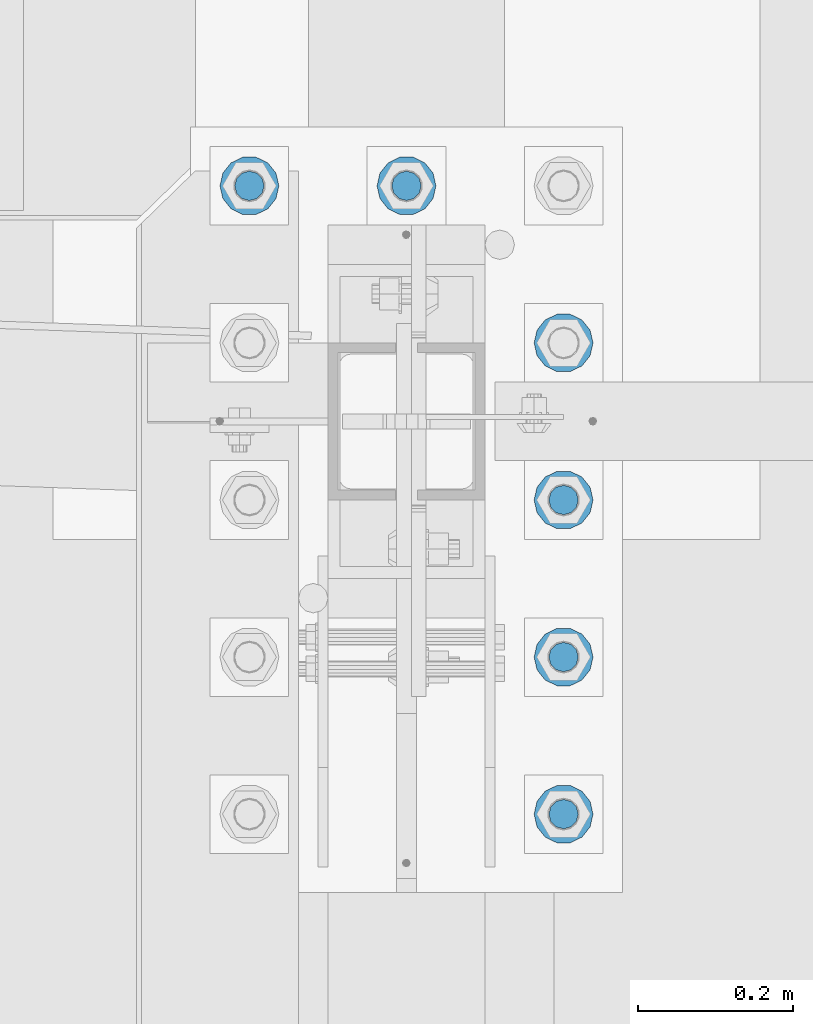
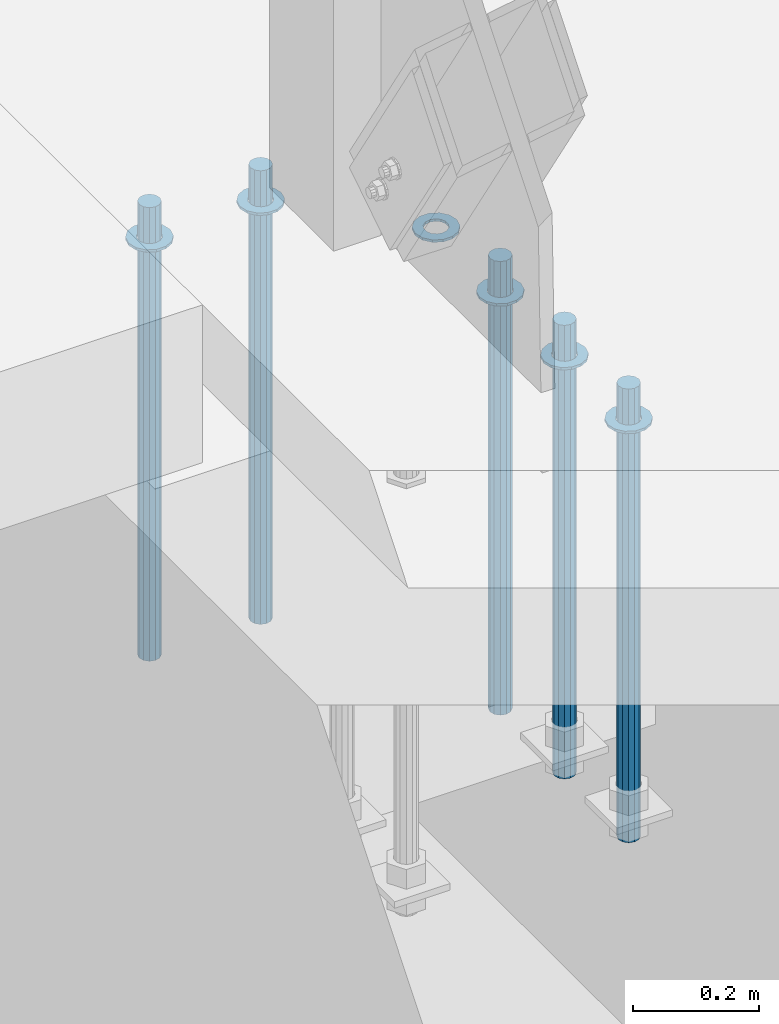
# One storey, part 926 of 1763: 11 columns, 1 element without a shape of its own.
"""IFC2X3 building model written with IfcOpenShell, lengths in millimetres."""

from ifc_helpers import new_model, si_unit, frame, origin_with_axes, place, context, subcontext, project, spatial, faceted_brep, material, type_object, element, aggregate, save


model = new_model("IFC2X3")

# Units and contexts
model_context = context("Model", 3, precision=1e-05, world=origin_with_axes())
body_context = subcontext(model_context, "Body", "Model", "MODEL_VIEW")
ifc_project = project(units=[si_unit("LENGTHUNIT", "METRE", prefix="MILLI"), si_unit("AREAUNIT", "SQUARE_METRE"), si_unit("VOLUMEUNIT", "CUBIC_METRE"), si_unit("MASSUNIT", "GRAM", prefix="KILO"), si_unit("TIMEUNIT", "SECOND"), si_unit("PLANEANGLEUNIT", "RADIAN"), si_unit("SOLIDANGLEUNIT", "STERADIAN"), si_unit("THERMODYNAMICTEMPERATUREUNIT", "DEGREE_CELSIUS"), si_unit("LUMINOUSINTENSITYUNIT", "LUMEN")], contexts=[model_context])

# Site, building, storey
site_placement = place(None, origin_with_axes())
site = spatial("IfcSite", under=ifc_project, at=site_placement, CompositionType="ELEMENT")
building_placement = place(site_placement, origin_with_axes())
building = spatial("IfcBuilding", under=site, at=building_placement, Name="Undefined", CompositionType="ELEMENT")
storey_placement = place(building_placement, origin_with_axes())
storey = spatial("IfcBuildingStorey", under=building, at=storey_placement, Name="Undefined", CompositionType="ELEMENT", Elevation=0.0)

# Assembly, columns
assembly_placement = place(storey_placement, origin_with_axes())
assembly = element("IfcElementAssembly", 1, at=assembly_placement, inside=storey, Name="TEMPLATE", AssemblyPlace="NOTDEFINED", PredefinedType="RIGID_FRAME")
ifc_material_1 = material(Name="STEEL/F436")
column_type_1 = type_object("IfcColumnType", Name="1-1/2_WASHER", PredefinedType="NOTDEFINED")
column_1_placement = place(assembly_placement, frame((-87172.2372736984, 8026.40000000001, 5151.43750000001), z_axis=(0.0, 1.0, 0.0), x_axis=(0.0, 0.0, -1.0)))
column_1 = element("IfcColumn", 2, at=column_1_placement, type_object=column_type_1, material=ifc_material_1, Name="WASHER", ObjectType="1-1/2_WASHER", context=body_context, shape_type="Brep", body=[
    faceted_brep([(0.0, -38.0999984741211, 0.0), (0.0, -34.3269124923099, -16.5309697983248), (4.76249999999982, -34.3269124923099, -16.5309697983248), (4.76249999999982, -38.0999984741211, 0.0), (0.0, -23.7549604994492, -29.7877782890519), (4.76249999999982, -23.7549604994492, -29.7877782890519), (0.0, -8.47804724419257, -37.1447519665053), (4.76249999999982, -8.47804724419257, -37.1447519665053), (0.0, 8.47804724419257, -37.1447519665053), (4.76249999999982, 8.47804724419257, -37.1447519665053), (0.0, 23.7549604994492, -29.7877782890519), (4.76249999999982, 23.7549604994492, -29.7877782890519), (0.0, 34.3269124923099, -16.5309697983248), (4.76249999999982, 34.3269124923099, -16.5309697983248), (0.0, 38.0999984741211, 0.0), (4.76249999999982, 38.0999984741211, 0.0), (0.0, 34.3269124923099, 16.5309697983248), (4.76249999999982, 34.3269124923099, 16.5309697983248), (0.0, 23.7549604994492, 29.7877782890519), (4.76249999999982, 23.7549604994492, 29.7877782890519), (0.0, 8.47804724419257, 37.1447519665053), (4.76249999999982, 8.47804724419257, 37.1447519665053), (0.0, -8.47804724419257, 37.1447519665053), (4.76249999999982, -8.47804724419257, 37.1447519665053), (0.0, -23.7549604994492, 29.7877782890519), (4.76249999999982, -23.7549604994492, 29.7877782890519), (0.0, -34.3269124923099, 16.5309697983248), (4.76249999999982, -34.3269124923099, 16.5309697983248), (0.0, 0.0, 20.6399993896484), (0.0, 8.95536011056538, 18.5959968835978), (4.76249999999982, 8.95536011056538, 18.5959968835978), (4.76249999999982, 0.0, 20.6399993896484), (0.0, 16.1370013209453, 12.8688291298167), (4.76249999999982, 16.1370013209453, 12.8688291298167), (0.0, 20.1225115123816, 4.59283194104137), (4.76249999999982, 20.1225115123816, 4.59283194104137), (0.0, 20.1225115123816, -4.59283194104319), (4.76249999999982, 20.1225115123816, -4.59283194104319), (0.0, 16.1370013209453, -12.8688291298167), (4.76249999999982, 16.1370013209453, -12.8688291298167), (0.0, 8.95536011056538, -18.5959968835978), (4.76249999999982, 8.95536011056538, -18.5959968835978), (0.0, 0.0, -20.6399993896484), (4.76249999999982, 0.0, -20.6399993896484), (0.0, -8.95536011056538, -18.5959968835978), (4.76249999999982, -8.95536011056538, -18.5959968835978), (0.0, -16.1370013209453, -12.8688291298167), (4.76249999999982, -16.1370013209453, -12.8688291298167), (0.0, -20.1225115123816, -4.59283194104137), (4.76249999999982, -20.1225115123816, -4.59283194104137), (0.0, -20.1225115123816, 4.59283194104319), (4.76249999999982, -20.1225115123816, 4.59283194104319), (0.0, -16.1370013209453, 12.8688291298167), (4.76249999999982, -16.1370013209453, 12.8688291298167), (0.0, -8.95536011056538, 18.5959968835978), (4.76249999999982, -8.95536011056538, 18.5959968835978)], [[[0, 1, 2, 3]], [[1, 4, 5, 2]], [[4, 6, 7, 5]], [[6, 8, 9, 7]], [[8, 10, 11, 9]], [[10, 12, 13, 11]], [[12, 14, 15, 13]], [[14, 16, 17, 15]], [[16, 18, 19, 17]], [[18, 20, 21, 19]], [[20, 22, 23, 21]], [[22, 24, 25, 23]], [[24, 26, 27, 25]], [[26, 0, 3, 27]], [[28, 29, 30, 31]], [[29, 32, 33, 30]], [[32, 34, 35, 33]], [[34, 36, 37, 35]], [[36, 38, 39, 37]], [[38, 40, 41, 39]], [[40, 42, 43, 41]], [[42, 44, 45, 43]], [[44, 46, 47, 45]], [[46, 48, 49, 47]], [[48, 50, 51, 49]], [[50, 52, 53, 51]], [[52, 54, 55, 53]], [[54, 28, 31, 55]], [[5, 7, 9, 11, 13, 15, 17, 19, 21, 23, 25, 27, 3, 2], [33, 35, 37, 39, 41, 43, 45, 47, 49, 51, 53, 55, 31, 30]], [[26, 24, 22, 20, 18, 16, 14, 12, 10, 8, 6, 4, 1, 0], [54, 52, 50, 48, 46, 44, 42, 40, 38, 36, 34, 32, 29, 28]]]),
])
column_2_placement = place(assembly_placement, frame((-87172.2372736984, 8229.60000000001, 5151.43750000001), z_axis=(0.0, 1.0, 0.0), x_axis=(0.0, 0.0, -1.0)))
column_2 = element("IfcColumn", 3, at=column_2_placement, type_object=column_type_1, material=ifc_material_1, Name="WASHER", ObjectType="1-1/2_WASHER", context=body_context, shape_type="Brep", body=[
    faceted_brep([(0.0, -38.0999984741211, 0.0), (0.0, -34.3269124923099, -16.5309697983248), (4.76249999999982, -34.3269124923099, -16.5309697983248), (4.76249999999982, -38.0999984741211, 0.0), (0.0, -23.7549604994492, -29.7877782890519), (4.76249999999982, -23.7549604994492, -29.7877782890519), (0.0, -8.47804724419257, -37.1447519665053), (4.76249999999982, -8.47804724419257, -37.1447519665053), (0.0, 8.47804724419257, -37.1447519665053), (4.76249999999982, 8.47804724419257, -37.1447519665053), (0.0, 23.7549604994492, -29.7877782890519), (4.76249999999982, 23.7549604994492, -29.7877782890519), (0.0, 34.3269124923099, -16.5309697983248), (4.76249999999982, 34.3269124923099, -16.5309697983248), (0.0, 38.0999984741211, 0.0), (4.76249999999982, 38.0999984741211, 0.0), (0.0, 34.3269124923099, 16.5309697983248), (4.76249999999982, 34.3269124923099, 16.5309697983248), (0.0, 23.7549604994492, 29.7877782890519), (4.76249999999982, 23.7549604994492, 29.7877782890519), (0.0, 8.47804724419257, 37.1447519665053), (4.76249999999982, 8.47804724419257, 37.1447519665053), (0.0, -8.47804724419257, 37.1447519665053), (4.76249999999982, -8.47804724419257, 37.1447519665053), (0.0, -23.7549604994492, 29.7877782890519), (4.76249999999982, -23.7549604994492, 29.7877782890519), (0.0, -34.3269124923099, 16.5309697983248), (4.76249999999982, -34.3269124923099, 16.5309697983248), (0.0, 0.0, 20.6399993896484), (0.0, 8.95536011056538, 18.5959968835978), (4.76249999999982, 8.95536011056538, 18.5959968835978), (4.76249999999982, 0.0, 20.6399993896484), (0.0, 16.1370013209453, 12.8688291298167), (4.76249999999982, 16.1370013209453, 12.8688291298167), (0.0, 20.1225115123816, 4.59283194104137), (4.76249999999982, 20.1225115123816, 4.59283194104137), (0.0, 20.1225115123816, -4.59283194104319), (4.76249999999982, 20.1225115123816, -4.59283194104319), (0.0, 16.1370013209453, -12.8688291298167), (4.76249999999982, 16.1370013209453, -12.8688291298167), (0.0, 8.95536011056538, -18.5959968835978), (4.76249999999982, 8.95536011056538, -18.5959968835978), (0.0, 0.0, -20.6399993896484), (4.76249999999982, 0.0, -20.6399993896484), (0.0, -8.95536011056538, -18.5959968835978), (4.76249999999982, -8.95536011056538, -18.5959968835978), (0.0, -16.1370013209453, -12.8688291298167), (4.76249999999982, -16.1370013209453, -12.8688291298167), (0.0, -20.1225115123816, -4.59283194104137), (4.76249999999982, -20.1225115123816, -4.59283194104137), (0.0, -20.1225115123816, 4.59283194104319), (4.76249999999982, -20.1225115123816, 4.59283194104319), (0.0, -16.1370013209453, 12.8688291298167), (4.76249999999982, -16.1370013209453, 12.8688291298167), (0.0, -8.95536011056538, 18.5959968835978), (4.76249999999982, -8.95536011056538, 18.5959968835978)], [[[0, 1, 2, 3]], [[1, 4, 5, 2]], [[4, 6, 7, 5]], [[6, 8, 9, 7]], [[8, 10, 11, 9]], [[10, 12, 13, 11]], [[12, 14, 15, 13]], [[14, 16, 17, 15]], [[16, 18, 19, 17]], [[18, 20, 21, 19]], [[20, 22, 23, 21]], [[22, 24, 25, 23]], [[24, 26, 27, 25]], [[26, 0, 3, 27]], [[28, 29, 30, 31]], [[29, 32, 33, 30]], [[32, 34, 35, 33]], [[34, 36, 37, 35]], [[36, 38, 39, 37]], [[38, 40, 41, 39]], [[40, 42, 43, 41]], [[42, 44, 45, 43]], [[44, 46, 47, 45]], [[46, 48, 49, 47]], [[48, 50, 51, 49]], [[50, 52, 53, 51]], [[52, 54, 55, 53]], [[54, 28, 31, 55]], [[5, 7, 9, 11, 13, 15, 17, 19, 21, 23, 25, 27, 3, 2], [33, 35, 37, 39, 41, 43, 45, 47, 49, 51, 53, 55, 31, 30]], [[26, 24, 22, 20, 18, 16, 14, 12, 10, 8, 6, 4, 1, 0], [54, 52, 50, 48, 46, 44, 42, 40, 38, 36, 34, 32, 29, 28]]]),
])
column_3_placement = place(assembly_placement, frame((-87172.2372736984, 8432.80000000001, 5151.43750000001), z_axis=(0.0, 1.0, 0.0), x_axis=(0.0, 0.0, -1.0)))
column_3 = element("IfcColumn", 4, at=column_3_placement, type_object=column_type_1, material=ifc_material_1, Name="WASHER", ObjectType="1-1/2_WASHER", context=body_context, shape_type="Brep", body=[
    faceted_brep([(0.0, -38.0999984741211, 0.0), (0.0, -34.3269124923099, -16.5309697983248), (4.76249999999982, -34.3269124923099, -16.5309697983248), (4.76249999999982, -38.0999984741211, 0.0), (0.0, -23.7549604994492, -29.7877782890519), (4.76249999999982, -23.7549604994492, -29.7877782890519), (0.0, -8.47804724419257, -37.1447519665053), (4.76249999999982, -8.47804724419257, -37.1447519665053), (0.0, 8.47804724419257, -37.1447519665053), (4.76249999999982, 8.47804724419257, -37.1447519665053), (0.0, 23.7549604994492, -29.7877782890519), (4.76249999999982, 23.7549604994492, -29.7877782890519), (0.0, 34.3269124923099, -16.5309697983248), (4.76249999999982, 34.3269124923099, -16.5309697983248), (0.0, 38.0999984741211, 0.0), (4.76249999999982, 38.0999984741211, 0.0), (0.0, 34.3269124923099, 16.5309697983248), (4.76249999999982, 34.3269124923099, 16.5309697983248), (0.0, 23.7549604994492, 29.7877782890519), (4.76249999999982, 23.7549604994492, 29.7877782890519), (0.0, 8.47804724419257, 37.1447519665053), (4.76249999999982, 8.47804724419257, 37.1447519665053), (0.0, -8.47804724419257, 37.1447519665053), (4.76249999999982, -8.47804724419257, 37.1447519665053), (0.0, -23.7549604994492, 29.7877782890519), (4.76249999999982, -23.7549604994492, 29.7877782890519), (0.0, -34.3269124923099, 16.5309697983248), (4.76249999999982, -34.3269124923099, 16.5309697983248), (0.0, 0.0, 20.6399993896484), (0.0, 8.95536011056538, 18.5959968835978), (4.76249999999982, 8.95536011056538, 18.5959968835978), (4.76249999999982, 0.0, 20.6399993896484), (0.0, 16.1370013209453, 12.8688291298167), (4.76249999999982, 16.1370013209453, 12.8688291298167), (0.0, 20.1225115123816, 4.59283194104137), (4.76249999999982, 20.1225115123816, 4.59283194104137), (0.0, 20.1225115123816, -4.59283194104319), (4.76249999999982, 20.1225115123816, -4.59283194104319), (0.0, 16.1370013209453, -12.8688291298167), (4.76249999999982, 16.1370013209453, -12.8688291298167), (0.0, 8.95536011056538, -18.5959968835978), (4.76249999999982, 8.95536011056538, -18.5959968835978), (0.0, 0.0, -20.6399993896484), (4.76249999999982, 0.0, -20.6399993896484), (0.0, -8.95536011056538, -18.5959968835978), (4.76249999999982, -8.95536011056538, -18.5959968835978), (0.0, -16.1370013209453, -12.8688291298167), (4.76249999999982, -16.1370013209453, -12.8688291298167), (0.0, -20.1225115123816, -4.59283194104137), (4.76249999999982, -20.1225115123816, -4.59283194104137), (0.0, -20.1225115123816, 4.59283194104319), (4.76249999999982, -20.1225115123816, 4.59283194104319), (0.0, -16.1370013209453, 12.8688291298167), (4.76249999999982, -16.1370013209453, 12.8688291298167), (0.0, -8.95536011056538, 18.5959968835978), (4.76249999999982, -8.95536011056538, 18.5959968835978)], [[[0, 1, 2, 3]], [[1, 4, 5, 2]], [[4, 6, 7, 5]], [[6, 8, 9, 7]], [[8, 10, 11, 9]], [[10, 12, 13, 11]], [[12, 14, 15, 13]], [[14, 16, 17, 15]], [[16, 18, 19, 17]], [[18, 20, 21, 19]], [[20, 22, 23, 21]], [[22, 24, 25, 23]], [[24, 26, 27, 25]], [[26, 0, 3, 27]], [[28, 29, 30, 31]], [[29, 32, 33, 30]], [[32, 34, 35, 33]], [[34, 36, 37, 35]], [[36, 38, 39, 37]], [[38, 40, 41, 39]], [[40, 42, 43, 41]], [[42, 44, 45, 43]], [[44, 46, 47, 45]], [[46, 48, 49, 47]], [[48, 50, 51, 49]], [[50, 52, 53, 51]], [[52, 54, 55, 53]], [[54, 28, 31, 55]], [[5, 7, 9, 11, 13, 15, 17, 19, 21, 23, 25, 27, 3, 2], [33, 35, 37, 39, 41, 43, 45, 47, 49, 51, 53, 55, 31, 30]], [[26, 24, 22, 20, 18, 16, 14, 12, 10, 8, 6, 4, 1, 0], [54, 52, 50, 48, 46, 44, 42, 40, 38, 36, 34, 32, 29, 28]]]),
])
column_4_placement = place(assembly_placement, frame((-87172.2372736984, 8636.00000000001, 5151.43750000001), z_axis=(0.0, 1.0, 0.0), x_axis=(0.0, 0.0, -1.0)))
column_4 = element("IfcColumn", 5, at=column_4_placement, type_object=column_type_1, material=ifc_material_1, Name="WASHER", ObjectType="1-1/2_WASHER", context=body_context, shape_type="Brep", body=[
    faceted_brep([(0.0, -38.0999984741211, 0.0), (0.0, -34.3269124923099, -16.5309697983248), (4.76249999999982, -34.3269124923099, -16.5309697983248), (4.76249999999982, -38.0999984741211, 0.0), (0.0, -23.7549604994492, -29.7877782890519), (4.76249999999982, -23.7549604994492, -29.7877782890519), (0.0, -8.47804724419257, -37.1447519665053), (4.76249999999982, -8.47804724419257, -37.1447519665053), (0.0, 8.47804724419257, -37.1447519665053), (4.76249999999982, 8.47804724419257, -37.1447519665053), (0.0, 23.7549604994492, -29.7877782890519), (4.76249999999982, 23.7549604994492, -29.7877782890519), (0.0, 34.3269124923099, -16.5309697983248), (4.76249999999982, 34.3269124923099, -16.5309697983248), (0.0, 38.0999984741211, 0.0), (4.76249999999982, 38.0999984741211, 0.0), (0.0, 34.3269124923099, 16.5309697983248), (4.76249999999982, 34.3269124923099, 16.5309697983248), (0.0, 23.7549604994492, 29.7877782890519), (4.76249999999982, 23.7549604994492, 29.7877782890519), (0.0, 8.47804724419257, 37.1447519665053), (4.76249999999982, 8.47804724419257, 37.1447519665053), (0.0, -8.47804724419257, 37.1447519665053), (4.76249999999982, -8.47804724419257, 37.1447519665053), (0.0, -23.7549604994492, 29.7877782890519), (4.76249999999982, -23.7549604994492, 29.7877782890519), (0.0, -34.3269124923099, 16.5309697983248), (4.76249999999982, -34.3269124923099, 16.5309697983248), (0.0, 0.0, 20.6399993896484), (0.0, 8.95536011056538, 18.5959968835978), (4.76249999999982, 8.95536011056538, 18.5959968835978), (4.76249999999982, 0.0, 20.6399993896484), (0.0, 16.1370013209453, 12.8688291298167), (4.76249999999982, 16.1370013209453, 12.8688291298167), (0.0, 20.1225115123816, 4.59283194104137), (4.76249999999982, 20.1225115123816, 4.59283194104137), (0.0, 20.1225115123816, -4.59283194104319), (4.76249999999982, 20.1225115123816, -4.59283194104319), (0.0, 16.1370013209453, -12.8688291298167), (4.76249999999982, 16.1370013209453, -12.8688291298167), (0.0, 8.95536011056538, -18.5959968835978), (4.76249999999982, 8.95536011056538, -18.5959968835978), (0.0, 0.0, -20.6399993896484), (4.76249999999982, 0.0, -20.6399993896484), (0.0, -8.95536011056538, -18.5959968835978), (4.76249999999982, -8.95536011056538, -18.5959968835978), (0.0, -16.1370013209453, -12.8688291298167), (4.76249999999982, -16.1370013209453, -12.8688291298167), (0.0, -20.1225115123816, -4.59283194104137), (4.76249999999982, -20.1225115123816, -4.59283194104137), (0.0, -20.1225115123816, 4.59283194104319), (4.76249999999982, -20.1225115123816, 4.59283194104319), (0.0, -16.1370013209453, 12.8688291298167), (4.76249999999982, -16.1370013209453, 12.8688291298167), (0.0, -8.95536011056538, 18.5959968835978), (4.76249999999982, -8.95536011056538, 18.5959968835978)], [[[0, 1, 2, 3]], [[1, 4, 5, 2]], [[4, 6, 7, 5]], [[6, 8, 9, 7]], [[8, 10, 11, 9]], [[10, 12, 13, 11]], [[12, 14, 15, 13]], [[14, 16, 17, 15]], [[16, 18, 19, 17]], [[18, 20, 21, 19]], [[20, 22, 23, 21]], [[22, 24, 25, 23]], [[24, 26, 27, 25]], [[26, 0, 3, 27]], [[28, 29, 30, 31]], [[29, 32, 33, 30]], [[32, 34, 35, 33]], [[34, 36, 37, 35]], [[36, 38, 39, 37]], [[38, 40, 41, 39]], [[40, 42, 43, 41]], [[42, 44, 45, 43]], [[44, 46, 47, 45]], [[46, 48, 49, 47]], [[48, 50, 51, 49]], [[50, 52, 53, 51]], [[52, 54, 55, 53]], [[54, 28, 31, 55]], [[5, 7, 9, 11, 13, 15, 17, 19, 21, 23, 25, 27, 3, 2], [33, 35, 37, 39, 41, 43, 45, 47, 49, 51, 53, 55, 31, 30]], [[26, 24, 22, 20, 18, 16, 14, 12, 10, 8, 6, 4, 1, 0], [54, 52, 50, 48, 46, 44, 42, 40, 38, 36, 34, 32, 29, 28]]]),
])
column_5_placement = place(assembly_placement, frame((-87578.6372736983, 8839.20000000001, 5151.43750000001), z_axis=(0.0, -1.0, 0.0), x_axis=(0.0, 0.0, -1.0)))
column_5 = element("IfcColumn", 6, at=column_5_placement, type_object=column_type_1, material=ifc_material_1, Name="WASHER", ObjectType="1-1/2_WASHER", context=body_context, shape_type="Brep", body=[
    faceted_brep([(0.0, -38.0999984741211, 0.0), (0.0, -34.3269124923099, -16.5309697983248), (4.76249999999982, -34.3269124923099, -16.5309697983248), (4.76249999999982, -38.0999984741211, 0.0), (0.0, -23.7549604994492, -29.7877782890519), (4.76249999999982, -23.7549604994492, -29.7877782890519), (0.0, -8.47804724419257, -37.1447519665053), (4.76249999999982, -8.47804724419257, -37.1447519665053), (0.0, 8.47804724419257, -37.1447519665053), (4.76249999999982, 8.47804724419257, -37.1447519665053), (0.0, 23.7549604994492, -29.7877782890519), (4.76249999999982, 23.7549604994492, -29.7877782890519), (0.0, 34.3269124923099, -16.5309697983248), (4.76249999999982, 34.3269124923099, -16.5309697983248), (0.0, 38.0999984741211, 0.0), (4.76249999999982, 38.0999984741211, 0.0), (0.0, 34.3269124923099, 16.5309697983248), (4.76249999999982, 34.3269124923099, 16.5309697983248), (0.0, 23.7549604994492, 29.7877782890519), (4.76249999999982, 23.7549604994492, 29.7877782890519), (0.0, 8.47804724419257, 37.1447519665053), (4.76249999999982, 8.47804724419257, 37.1447519665053), (0.0, -8.47804724419257, 37.1447519665053), (4.76249999999982, -8.47804724419257, 37.1447519665053), (0.0, -23.7549604994492, 29.7877782890519), (4.76249999999982, -23.7549604994492, 29.7877782890519), (0.0, -34.3269124923099, 16.5309697983248), (4.76249999999982, -34.3269124923099, 16.5309697983248), (0.0, 0.0, 20.6399993896484), (0.0, 8.95536011056538, 18.5959968835978), (4.76249999999982, 8.95536011056538, 18.5959968835978), (4.76249999999982, 0.0, 20.6399993896484), (0.0, 16.1370013209453, 12.8688291298167), (4.76249999999982, 16.1370013209453, 12.8688291298167), (0.0, 20.1225115123816, 4.59283194104137), (4.76249999999982, 20.1225115123816, 4.59283194104137), (0.0, 20.1225115123816, -4.59283194104319), (4.76249999999982, 20.1225115123816, -4.59283194104319), (0.0, 16.1370013209453, -12.8688291298167), (4.76249999999982, 16.1370013209453, -12.8688291298167), (0.0, 8.95536011056538, -18.5959968835978), (4.76249999999982, 8.95536011056538, -18.5959968835978), (0.0, 0.0, -20.6399993896484), (4.76249999999982, 0.0, -20.6399993896484), (0.0, -8.95536011056538, -18.5959968835978), (4.76249999999982, -8.95536011056538, -18.5959968835978), (0.0, -16.1370013209453, -12.8688291298167), (4.76249999999982, -16.1370013209453, -12.8688291298167), (0.0, -20.1225115123816, -4.59283194104137), (4.76249999999982, -20.1225115123816, -4.59283194104137), (0.0, -20.1225115123816, 4.59283194104319), (4.76249999999982, -20.1225115123816, 4.59283194104319), (0.0, -16.1370013209453, 12.8688291298167), (4.76249999999982, -16.1370013209453, 12.8688291298167), (0.0, -8.95536011056538, 18.5959968835978), (4.76249999999982, -8.95536011056538, 18.5959968835978)], [[[0, 1, 2, 3]], [[1, 4, 5, 2]], [[4, 6, 7, 5]], [[6, 8, 9, 7]], [[8, 10, 11, 9]], [[10, 12, 13, 11]], [[12, 14, 15, 13]], [[14, 16, 17, 15]], [[16, 18, 19, 17]], [[18, 20, 21, 19]], [[20, 22, 23, 21]], [[22, 24, 25, 23]], [[24, 26, 27, 25]], [[26, 0, 3, 27]], [[28, 29, 30, 31]], [[29, 32, 33, 30]], [[32, 34, 35, 33]], [[34, 36, 37, 35]], [[36, 38, 39, 37]], [[38, 40, 41, 39]], [[40, 42, 43, 41]], [[42, 44, 45, 43]], [[44, 46, 47, 45]], [[46, 48, 49, 47]], [[48, 50, 51, 49]], [[50, 52, 53, 51]], [[52, 54, 55, 53]], [[54, 28, 31, 55]], [[5, 7, 9, 11, 13, 15, 17, 19, 21, 23, 25, 27, 3, 2], [33, 35, 37, 39, 41, 43, 45, 47, 49, 51, 53, 55, 31, 30]], [[26, 24, 22, 20, 18, 16, 14, 12, 10, 8, 6, 4, 1, 0], [54, 52, 50, 48, 46, 44, 42, 40, 38, 36, 34, 32, 29, 28]]]),
])
column_6_placement = place(assembly_placement, frame((-87375.4372736983, 8839.20000000001, 5151.43750000001), z_axis=(0.0, -1.0, 0.0), x_axis=(0.0, 0.0, -1.0)))
column_6 = element("IfcColumn", 7, at=column_6_placement, type_object=column_type_1, material=ifc_material_1, Name="WASHER", ObjectType="1-1/2_WASHER", context=body_context, shape_type="Brep", body=[
    faceted_brep([(0.0, -38.0999984741211, 0.0), (0.0, -34.3269124923099, -16.5309697983248), (4.76249999999982, -34.3269124923099, -16.5309697983248), (4.76249999999982, -38.0999984741211, 0.0), (0.0, -23.7549604994492, -29.7877782890519), (4.76249999999982, -23.7549604994492, -29.7877782890519), (0.0, -8.47804724419257, -37.1447519665053), (4.76249999999982, -8.47804724419257, -37.1447519665053), (0.0, 8.47804724419257, -37.1447519665053), (4.76249999999982, 8.47804724419257, -37.1447519665053), (0.0, 23.7549604994492, -29.7877782890519), (4.76249999999982, 23.7549604994492, -29.7877782890519), (0.0, 34.3269124923099, -16.5309697983248), (4.76249999999982, 34.3269124923099, -16.5309697983248), (0.0, 38.0999984741211, 0.0), (4.76249999999982, 38.0999984741211, 0.0), (0.0, 34.3269124923099, 16.5309697983248), (4.76249999999982, 34.3269124923099, 16.5309697983248), (0.0, 23.7549604994492, 29.7877782890519), (4.76249999999982, 23.7549604994492, 29.7877782890519), (0.0, 8.47804724419257, 37.1447519665053), (4.76249999999982, 8.47804724419257, 37.1447519665053), (0.0, -8.47804724419257, 37.1447519665053), (4.76249999999982, -8.47804724419257, 37.1447519665053), (0.0, -23.7549604994492, 29.7877782890519), (4.76249999999982, -23.7549604994492, 29.7877782890519), (0.0, -34.3269124923099, 16.5309697983248), (4.76249999999982, -34.3269124923099, 16.5309697983248), (0.0, 0.0, 20.6399993896484), (0.0, 8.95536011056538, 18.5959968835978), (4.76249999999982, 8.95536011056538, 18.5959968835978), (4.76249999999982, 0.0, 20.6399993896484), (0.0, 16.1370013209453, 12.8688291298167), (4.76249999999982, 16.1370013209453, 12.8688291298167), (0.0, 20.1225115123816, 4.59283194104137), (4.76249999999982, 20.1225115123816, 4.59283194104137), (0.0, 20.1225115123816, -4.59283194104319), (4.76249999999982, 20.1225115123816, -4.59283194104319), (0.0, 16.1370013209453, -12.8688291298167), (4.76249999999982, 16.1370013209453, -12.8688291298167), (0.0, 8.95536011056538, -18.5959968835978), (4.76249999999982, 8.95536011056538, -18.5959968835978), (0.0, 0.0, -20.6399993896484), (4.76249999999982, 0.0, -20.6399993896484), (0.0, -8.95536011056538, -18.5959968835978), (4.76249999999982, -8.95536011056538, -18.5959968835978), (0.0, -16.1370013209453, -12.8688291298167), (4.76249999999982, -16.1370013209453, -12.8688291298167), (0.0, -20.1225115123816, -4.59283194104137), (4.76249999999982, -20.1225115123816, -4.59283194104137), (0.0, -20.1225115123816, 4.59283194104319), (4.76249999999982, -20.1225115123816, 4.59283194104319), (0.0, -16.1370013209453, 12.8688291298167), (4.76249999999982, -16.1370013209453, 12.8688291298167), (0.0, -8.95536011056538, 18.5959968835978), (4.76249999999982, -8.95536011056538, 18.5959968835978)], [[[0, 1, 2, 3]], [[1, 4, 5, 2]], [[4, 6, 7, 5]], [[6, 8, 9, 7]], [[8, 10, 11, 9]], [[10, 12, 13, 11]], [[12, 14, 15, 13]], [[14, 16, 17, 15]], [[16, 18, 19, 17]], [[18, 20, 21, 19]], [[20, 22, 23, 21]], [[22, 24, 25, 23]], [[24, 26, 27, 25]], [[26, 0, 3, 27]], [[28, 29, 30, 31]], [[29, 32, 33, 30]], [[32, 34, 35, 33]], [[34, 36, 37, 35]], [[36, 38, 39, 37]], [[38, 40, 41, 39]], [[40, 42, 43, 41]], [[42, 44, 45, 43]], [[44, 46, 47, 45]], [[46, 48, 49, 47]], [[48, 50, 51, 49]], [[50, 52, 53, 51]], [[52, 54, 55, 53]], [[54, 28, 31, 55]], [[5, 7, 9, 11, 13, 15, 17, 19, 21, 23, 25, 27, 3, 2], [33, 35, 37, 39, 41, 43, 45, 47, 49, 51, 53, 55, 31, 30]], [[26, 24, 22, 20, 18, 16, 14, 12, 10, 8, 6, 4, 1, 0], [54, 52, 50, 48, 46, 44, 42, 40, 38, 36, 34, 32, 29, 28]]]),
])
ifc_material_2 = material(Name="STEEL/F1554-GR.55")
column_type_2 = type_object("IfcColumnType", PredefinedType="NOTDEFINED")
column_7_placement = place(assembly_placement, frame((-87172.2372736984, 8026.40000000001, 5219.70000000001), z_axis=(0.0, 1.0, 0.0), x_axis=(0.0, 0.0, -1.0)))
column_7 = element("IfcColumn", 8, at=column_7_placement, type_object=column_type_2, material=ifc_material_2, Name="ALL THREADED ROD", context=body_context, shape_type="Brep", body=[
    faceted_brep([(0.0, -19.0500000000029, 0.0), (0.0, -16.4977839420899, -9.52500000000146), (876.299, -16.4977839420899, -9.52499999999964), (876.299, -19.0500000000029, 0.0), (0.0, -9.52499999999418, -16.4977839420935), (876.299, -9.52499999999418, -16.4977839420935), (1.45519152283669e-11, 1.81898940354586e-12, -19.0499999999993), (876.299, 0.0, -19.0500000000002), (0.0, 9.52499999999418, -16.4977839420935), (876.299, 9.52499999999418, -16.4977839420935), (0.0, 16.4977839420899, -9.52500000000146), (876.299, 16.4977839420899, -9.52499999999964), (0.0, 19.0500000000029, 0.0), (876.299, 19.0500000000029, 0.0), (0.0, 16.4977839420899, 9.52500000000146), (876.299, 16.4977839420899, 9.52499999999964), (0.0, 9.52499999999418, 16.4977839420935), (876.299, 9.52499999999418, 16.4977839420935), (1.45519152283669e-11, 1.81898940354586e-12, 19.0499999999993), (876.299, 0.0, 19.0500000000002), (0.0, -9.52499999999418, 16.4977839420935), (876.299, -9.52499999999418, 16.4977839420935), (0.0, -16.4977839420899, 9.52500000000146), (876.299, -16.4977839420899, 9.52499999999964)], [[[0, 1, 2, 3]], [[1, 4, 5, 2]], [[4, 6, 7, 5]], [[6, 8, 9, 7]], [[8, 10, 11, 9]], [[10, 12, 13, 11]], [[12, 14, 15, 13]], [[14, 16, 17, 15]], [[16, 18, 19, 17]], [[18, 20, 21, 19]], [[20, 22, 23, 21]], [[22, 0, 3, 23]], [[5, 7, 9, 11, 13, 15, 17, 19, 21, 23, 3, 2]], [[22, 20, 18, 16, 14, 12, 10, 8, 6, 4, 1, 0]]]),
])
column_8_placement = place(assembly_placement, frame((-87172.2372736984, 8229.60000000001, 5219.70000000001), z_axis=(0.0, 1.0, 0.0), x_axis=(0.0, 0.0, -1.0)))
column_8 = element("IfcColumn", 9, at=column_8_placement, type_object=column_type_2, material=ifc_material_2, Name="ALL THREADED ROD", context=body_context, shape_type="Brep", body=[
    faceted_brep([(0.0, -19.0500000000029, 0.0), (0.0, -16.4977839420899, -9.52500000000146), (876.299, -16.4977839420899, -9.52499999999964), (876.299, -19.0500000000029, 0.0), (0.0, -9.52499999999418, -16.4977839420935), (876.299, -9.52499999999418, -16.4977839420935), (1.45519152283669e-11, 1.81898940354586e-12, -19.0499999999993), (876.299, 0.0, -19.0500000000002), (0.0, 9.52499999999418, -16.4977839420935), (876.299, 9.52499999999418, -16.4977839420935), (0.0, 16.4977839420899, -9.52500000000146), (876.299, 16.4977839420899, -9.52499999999964), (0.0, 19.0500000000029, 0.0), (876.299, 19.0500000000029, 0.0), (0.0, 16.4977839420899, 9.52500000000146), (876.299, 16.4977839420899, 9.52499999999964), (0.0, 9.52499999999418, 16.4977839420935), (876.299, 9.52499999999418, 16.4977839420935), (1.45519152283669e-11, 1.81898940354586e-12, 19.0499999999993), (876.299, 0.0, 19.0500000000002), (0.0, -9.52499999999418, 16.4977839420935), (876.299, -9.52499999999418, 16.4977839420935), (0.0, -16.4977839420899, 9.52500000000146), (876.299, -16.4977839420899, 9.52499999999964)], [[[0, 1, 2, 3]], [[1, 4, 5, 2]], [[4, 6, 7, 5]], [[6, 8, 9, 7]], [[8, 10, 11, 9]], [[10, 12, 13, 11]], [[12, 14, 15, 13]], [[14, 16, 17, 15]], [[16, 18, 19, 17]], [[18, 20, 21, 19]], [[20, 22, 23, 21]], [[22, 0, 3, 23]], [[5, 7, 9, 11, 13, 15, 17, 19, 21, 23, 3, 2]], [[22, 20, 18, 16, 14, 12, 10, 8, 6, 4, 1, 0]]]),
])
column_9_placement = place(assembly_placement, frame((-87172.2372736984, 8432.80000000001, 5219.70000000001), z_axis=(0.0, 1.0, 0.0), x_axis=(0.0, 0.0, -1.0)))
column_9 = element("IfcColumn", 10, at=column_9_placement, type_object=column_type_2, material=ifc_material_2, Name="ALL THREADED ROD", context=body_context, shape_type="Brep", body=[
    faceted_brep([(0.0, -19.0500000000029, 0.0), (0.0, -16.4977839420899, -9.52500000000146), (876.299, -16.4977839420899, -9.52499999999964), (876.299, -19.0500000000029, 0.0), (0.0, -9.52499999999418, -16.4977839420935), (876.299, -9.52499999999418, -16.4977839420935), (1.45519152283669e-11, 1.81898940354586e-12, -19.0499999999993), (876.299, 0.0, -19.0500000000002), (0.0, 9.52499999999418, -16.4977839420935), (876.299, 9.52499999999418, -16.4977839420935), (0.0, 16.4977839420899, -9.52500000000146), (876.299, 16.4977839420899, -9.52499999999964), (0.0, 19.0500000000029, 0.0), (876.299, 19.0500000000029, 0.0), (0.0, 16.4977839420899, 9.52500000000146), (876.299, 16.4977839420899, 9.52499999999964), (0.0, 9.52499999999418, 16.4977839420935), (876.299, 9.52499999999418, 16.4977839420935), (1.45519152283669e-11, 1.81898940354586e-12, 19.0499999999993), (876.299, 0.0, 19.0500000000002), (0.0, -9.52499999999418, 16.4977839420935), (876.299, -9.52499999999418, 16.4977839420935), (0.0, -16.4977839420899, 9.52500000000146), (876.299, -16.4977839420899, 9.52499999999964)], [[[0, 1, 2, 3]], [[1, 4, 5, 2]], [[4, 6, 7, 5]], [[6, 8, 9, 7]], [[8, 10, 11, 9]], [[10, 12, 13, 11]], [[12, 14, 15, 13]], [[14, 16, 17, 15]], [[16, 18, 19, 17]], [[18, 20, 21, 19]], [[20, 22, 23, 21]], [[22, 0, 3, 23]], [[5, 7, 9, 11, 13, 15, 17, 19, 21, 23, 3, 2]], [[22, 20, 18, 16, 14, 12, 10, 8, 6, 4, 1, 0]]]),
])
column_10_placement = place(assembly_placement, frame((-87578.6372736983, 8839.20000000001, 5219.70000000001), z_axis=(0.0, -1.0, 0.0), x_axis=(0.0, 0.0, -1.0)))
column_10 = element("IfcColumn", 11, at=column_10_placement, type_object=column_type_2, material=ifc_material_2, Name="ALL THREADED ROD", context=body_context, shape_type="Brep", body=[
    faceted_brep([(0.0, -19.0500000000029, 0.0), (0.0, -16.4977839420899, -9.52500000000146), (876.299, -16.4977839420899, -9.52499999999964), (876.299, -19.0500000000029, 0.0), (0.0, -9.52499999999418, -16.4977839420935), (876.299, -9.52499999999418, -16.4977839420935), (1.45519152283669e-11, 1.81898940354586e-12, -19.0499999999993), (876.299, 0.0, -19.0500000000002), (0.0, 9.52499999999418, -16.4977839420935), (876.299, 9.52499999999418, -16.4977839420935), (0.0, 16.4977839420899, -9.52500000000146), (876.299, 16.4977839420899, -9.52499999999964), (0.0, 19.0500000000029, 0.0), (876.299, 19.0500000000029, 0.0), (0.0, 16.4977839420899, 9.52500000000146), (876.299, 16.4977839420899, 9.52499999999964), (0.0, 9.52499999999418, 16.4977839420935), (876.299, 9.52499999999418, 16.4977839420935), (1.45519152283669e-11, 1.81898940354586e-12, 19.0499999999993), (876.299, 0.0, 19.0500000000002), (0.0, -9.52499999999418, 16.4977839420935), (876.299, -9.52499999999418, 16.4977839420935), (0.0, -16.4977839420899, 9.52500000000146), (876.299, -16.4977839420899, 9.52499999999964)], [[[0, 1, 2, 3]], [[1, 4, 5, 2]], [[4, 6, 7, 5]], [[6, 8, 9, 7]], [[8, 10, 11, 9]], [[10, 12, 13, 11]], [[12, 14, 15, 13]], [[14, 16, 17, 15]], [[16, 18, 19, 17]], [[18, 20, 21, 19]], [[20, 22, 23, 21]], [[22, 0, 3, 23]], [[5, 7, 9, 11, 13, 15, 17, 19, 21, 23, 3, 2]], [[22, 20, 18, 16, 14, 12, 10, 8, 6, 4, 1, 0]]]),
])
column_11_placement = place(assembly_placement, frame((-87375.4372736983, 8839.20000000001, 5219.70000000001), z_axis=(0.0, -1.0, 0.0), x_axis=(0.0, 0.0, -1.0)))
column_11 = element("IfcColumn", 12, at=column_11_placement, type_object=column_type_2, material=ifc_material_2, Name="ALL THREADED ROD", context=body_context, shape_type="Brep", body=[
    faceted_brep([(0.0, -19.0500000000029, 0.0), (0.0, -16.4977839420899, -9.52500000000146), (876.299, -16.4977839420899, -9.52499999999964), (876.299, -19.0500000000029, 0.0), (0.0, -9.52499999999418, -16.4977839420935), (876.299, -9.52499999999418, -16.4977839420935), (1.45519152283669e-11, 1.81898940354586e-12, -19.0499999999993), (876.299, 0.0, -19.0500000000002), (0.0, 9.52499999999418, -16.4977839420935), (876.299, 9.52499999999418, -16.4977839420935), (0.0, 16.4977839420899, -9.52500000000146), (876.299, 16.4977839420899, -9.52499999999964), (0.0, 19.0500000000029, 0.0), (876.299, 19.0500000000029, 0.0), (0.0, 16.4977839420899, 9.52500000000146), (876.299, 16.4977839420899, 9.52499999999964), (0.0, 9.52499999999418, 16.4977839420935), (876.299, 9.52499999999418, 16.4977839420935), (1.45519152283669e-11, 1.81898940354586e-12, 19.0499999999993), (876.299, 0.0, 19.0500000000002), (0.0, -9.52499999999418, 16.4977839420935), (876.299, -9.52499999999418, 16.4977839420935), (0.0, -16.4977839420899, 9.52500000000146), (876.299, -16.4977839420899, 9.52499999999964)], [[[0, 1, 2, 3]], [[1, 4, 5, 2]], [[4, 6, 7, 5]], [[6, 8, 9, 7]], [[8, 10, 11, 9]], [[10, 12, 13, 11]], [[12, 14, 15, 13]], [[14, 16, 17, 15]], [[16, 18, 19, 17]], [[18, 20, 21, 19]], [[20, 22, 23, 21]], [[22, 0, 3, 23]], [[5, 7, 9, 11, 13, 15, 17, 19, 21, 23, 3, 2]], [[22, 20, 18, 16, 14, 12, 10, 8, 6, 4, 1, 0]]]),
])
aggregate(assembly, [column_1, column_7, column_2, column_8, column_3, column_9, column_4, column_5, column_10, column_6, column_11])

save(model, "model.ifc")
